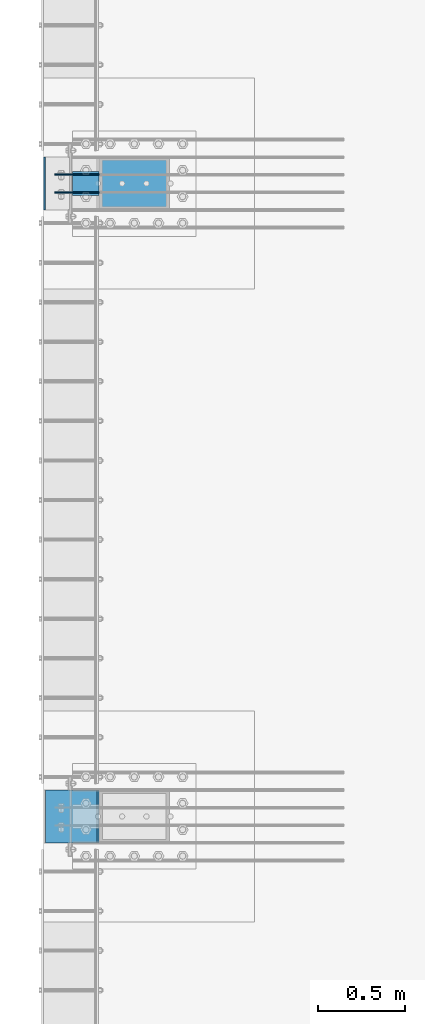
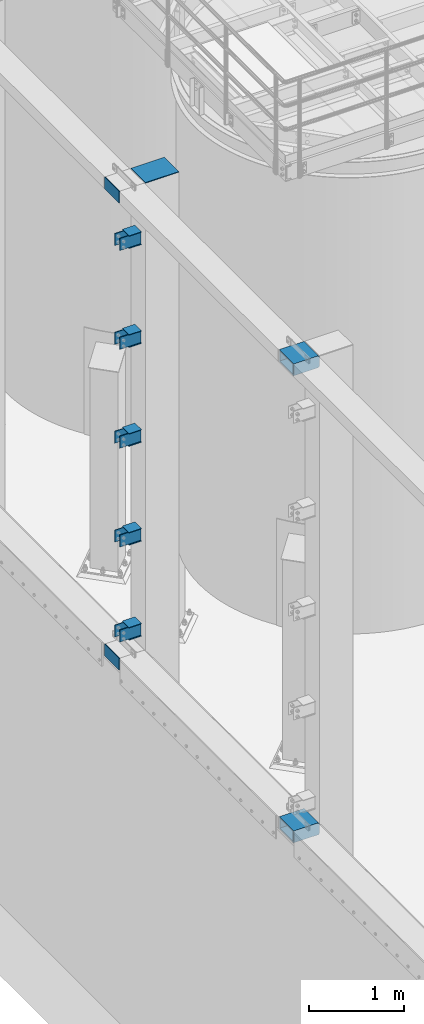
# One storey, part 1091 of 1876: 25 beams, 2 elements without a shape of their own.
"""IFC2X3 building model written with IfcOpenShell, lengths in millimetres."""

import ifcopenshell
import ifcopenshell.guid

model = None  # the IFC model being written
_history = None  # IfcOwnerHistory: only IFC2X3 demands one
_inside = {}  # id of a spatial element -> (the spatial element, [elements in it])
_under = {}  # id of a project, library or spatial element -> (it, [spatial elements below it])
_declared = {}  # id of a project -> (the project, [libraries it declares])
_typed = {}  # id of a type object -> (the type object, [elements of that type])
_made_of = {}  # id of a material, layer set ... -> (it, [elements and type objects made of it])


def new_model(schema):
    """Start an empty IFC model of exactly this schema.

    Asked for "IFC4X3", IfcOpenShell would pick the latest addendum, in which some entities
    have other attributes; the version numbers below select the first issue.
    IFC2X3 requires an IfcOwnerHistory on every rooted entity: one is made here for all.
    """
    global model, _history
    if schema == "IFC4X3":
        model = ifcopenshell.file(schema_version=(4, 3, 0, 0))
    else:
        model = ifcopenshell.file(schema=schema)
    _inside.clear()
    _under.clear()
    _declared.clear()
    _typed.clear()
    _made_of.clear()
    _history = None
    if model.schema == "IFC2X3":
        org = make("IfcOrganization", Name="unknown")
        user = make(
            "IfcPersonAndOrganization",
            ThePerson=make("IfcPerson", FamilyName="unknown"),
            TheOrganization=org,
        )
        app = make(
            "IfcApplication",
            ApplicationDeveloper=org,
            Version="unknown",
            ApplicationFullName="unknown",
            ApplicationIdentifier="unknown",
        )
        _history = make(
            "IfcOwnerHistory",
            OwningUser=user,
            OwningApplication=app,
            ChangeAction="ADDED",
            CreationDate=0,
        )
    return model


def make(cls, **values):
    """One entity of the class cls with the attributes given. An attribute that is None is left unset."""
    return model.create_entity(
        cls, **{name: value for name, value in values.items() if value is not None}
    )


def rooted(cls, **values):
    """An entity with a GlobalId (a new one), such as an element, a storey or a relation."""
    return make(cls, GlobalId=ifcopenshell.guid.new(), OwnerHistory=_history, **values)


def si_unit(unit_type, name, prefix=None):
    """IfcSIUnit, for example si_unit("LENGTHUNIT", "METRE", prefix="MILLI")."""
    return make("IfcSIUnit", UnitType=unit_type, Prefix=prefix, Name=name)


def assignment(units):
    """IfcUnitAssignment: the units of a project."""
    return None if units is None else make("IfcUnitAssignment", Units=units)


def point(xyz):
    """IfcCartesianPoint."""
    return None if xyz is None else make("IfcCartesianPoint", Coordinates=xyz)


def direction(xyz):
    """IfcDirection."""
    return None if xyz is None else make("IfcDirection", DirectionRatios=xyz)


def frame(location, z_axis=None, x_axis=None):
    """IfcAxis2Placement3D, a coordinate frame: its origin and axes. An axis left out is left unset."""
    return make(
        "IfcAxis2Placement3D",
        Location=point(location),
        Axis=direction(z_axis),
        RefDirection=direction(x_axis),
    )


def origin_with_axes():
    """The frame at (0, 0, 0) with the z axis (0, 0, 1) and the x axis (1, 0, 0) written out."""
    return frame((0.0, 0.0, 0.0), z_axis=(0.0, 0.0, 1.0), x_axis=(1.0, 0.0, 0.0))


def place(relative_to, where):
    """IfcLocalPlacement: puts the frame where relative to a parent placement (None: the world)."""
    return make(
        "IfcLocalPlacement", PlacementRelTo=relative_to, RelativePlacement=where
    )


def context(
    kind, dimensions, precision=None, world=None, true_north=None, identifier=None
):
    """IfcGeometricRepresentationContext, for example the 3D "Model" context."""
    return make(
        "IfcGeometricRepresentationContext",
        ContextIdentifier=identifier,
        ContextType=kind,
        CoordinateSpaceDimension=dimensions,
        Precision=precision,
        WorldCoordinateSystem=world,
        TrueNorth=true_north,
    )


def subcontext(parent, identifier, kind, view, scale=None):
    """IfcGeometricRepresentationSubContext, for example "Body" below "Model"."""
    return make(
        "IfcGeometricRepresentationSubContext",
        ContextIdentifier=identifier,
        ContextType=kind,
        ParentContext=parent,
        TargetScale=scale,
        TargetView=view,
    )


def project(units=None, contexts=None):
    """IfcProject with its units and contexts."""
    return rooted(
        "IfcProject",
        Name="project",
        RepresentationContexts=contexts,
        UnitsInContext=assignment(units),
    )


def spatial(cls, under=None, at=None, **own):
    """A site, building, storey or space (cls), placed at a placement, below another one or the project."""
    s = rooted(cls, ObjectPlacement=at, **own)
    if under is not None:
        _under.setdefault(under.id(), (under, []))[1].append(s)
    return s


def faces_of(points, faces, orient=None, outer=None):
    """IfcFace entities. A face is a list of loops; a loop is a list of indices into points, from 0.

    orient and outer hold one flag for each loop. By default every Orientation is true, the
    first loop of a face is its IfcFaceOuterBound and the others are IfcFaceBound.
    """
    made = []
    for i, loops in enumerate(faces):
        bounds = []
        for j, loop in enumerate(loops):
            is_outer = j == 0 if outer is None else outer[i][j]
            bounds.append(
                make(
                    "IfcFaceOuterBound" if is_outer else "IfcFaceBound",
                    Bound=make("IfcPolyLoop", Polygon=[points[k] for k in loop]),
                    Orientation=True if orient is None else orient[i][j],
                )
            )
        made.append(make("IfcFace", Bounds=bounds))
    return made


def faceted_brep(points, faces, orient=None, outer=None, voids=None):
    """IfcFacetedBrep: a solid bounded by flat faces; with voids (closed shells), ...WithVoids."""
    shared = [point(p) for p in points]
    hull = make("IfcClosedShell", CfsFaces=faces_of(shared, faces, orient, outer))
    if voids is None:
        return make("IfcFacetedBrep", Outer=hull)
    return make(
        "IfcFacetedBrepWithVoids",
        Outer=hull,
        Voids=[
            make(cls, CfsFaces=faces_of(shared, fs, o, b)) for cls, fs, o, b in voids
        ],
    )


def shape(context_of_items, identifier, shape_type, items):
    """IfcShapeRepresentation: the items that make up one representation, for example the "Body"."""
    return make(
        "IfcShapeRepresentation",
        ContextOfItems=context_of_items,
        RepresentationIdentifier=identifier,
        RepresentationType=shape_type,
        Items=items,
    )


def material(Name=None, Category=None):
    """IfcMaterial."""
    return make("IfcMaterial", Name=Name, Category=Category)


def made_of(thing, what):
    """Note that an element or type object is made of a material, layer set ...; save() writes the relation."""
    if what is not None:
        _made_of.setdefault(what.id(), (what, []))[1].append(thing)
    return thing


def type_object(cls, material=None, **own):
    """A type object (cls), such as IfcWallType, which elements share."""
    return made_of(rooted(cls, **own), material)


def element(
    cls,
    number,
    at=None,
    inside=None,
    cuts=None,
    type_object=None,
    material=None,
    context=None,
    identifier="Body",
    shape_type=None,
    held_by="IfcProductDefinitionShape",
    body=None,
    shapes=None,
    **own,
):
    """One element of the class cls, such as IfcWall. Its Tag is "e" and its number.

    at: its placement. inside: the storey or other place that contains it. cuts: it is an
    opening in that element (IfcRelVoidsElement). A single representation is given by context,
    identifier, shape_type and body (its items); several are given by shapes. held_by: the class
    of the entity that holds the representations. save() writes the other relations.
    """
    e = rooted(cls, Tag="e%d" % number, ObjectPlacement=at, **own)
    if body is not None:
        shapes = [shape(context, identifier, shape_type, body)]
    if shapes is not None:
        e.Representation = make(held_by, Representations=shapes)
    if inside is not None:
        _inside.setdefault(inside.id(), (inside, []))[1].append(e)
    if cuts is not None:
        rooted(
            "IfcRelVoidsElement", RelatingBuildingElement=cuts, RelatedOpeningElement=e
        )
    if type_object is not None:
        _typed.setdefault(type_object.id(), (type_object, []))[1].append(e)
    return made_of(e, material)


def aggregate(whole, parts):
    """IfcRelAggregates: a whole, such as a stair, and the parts it consists of."""
    return rooted("IfcRelAggregates", RelatingObject=whole, RelatedObjects=parts)


def save(model, path):
    """Write the relations noted so far, then the file.

    IfcRelAggregates (storeys below a building ...), IfcRelContainedInSpatialStructure (elements
    in a storey), IfcRelDefinesByType, IfcRelAssociatesMaterial and IfcRelDeclares: one each for
    every whole, place, type object, material and project.
    """
    for whole, parts in _under.values():
        aggregate(whole, parts)
    for where, things in _inside.values():
        rooted(
            "IfcRelContainedInSpatialStructure",
            RelatedElements=things,
            RelatingStructure=where,
        )
    for kind, things in _typed.values():
        rooted("IfcRelDefinesByType", RelatedObjects=things, RelatingType=kind)
    for what, things in _made_of.values():
        rooted("IfcRelAssociatesMaterial", RelatedObjects=things, RelatingMaterial=what)
    for by, libraries in _declared.values():
        rooted("IfcRelDeclares", RelatingContext=by, RelatedDefinitions=libraries)
    model.write(path)


model = new_model("IFC2X3")

# Units and contexts
model_context = context("Model", 3, precision=1e-05, world=origin_with_axes())
body_context = subcontext(model_context, "Body", "Model", "MODEL_VIEW")
ifc_project = project(units=[si_unit("LENGTHUNIT", "METRE", prefix="MILLI"), si_unit("AREAUNIT", "SQUARE_METRE"), si_unit("VOLUMEUNIT", "CUBIC_METRE"), si_unit("MASSUNIT", "GRAM", prefix="KILO"), si_unit("TIMEUNIT", "SECOND"), si_unit("PLANEANGLEUNIT", "RADIAN"), si_unit("SOLIDANGLEUNIT", "STERADIAN"), si_unit("THERMODYNAMICTEMPERATUREUNIT", "DEGREE_CELSIUS"), si_unit("LUMINOUSINTENSITYUNIT", "LUMEN")], contexts=[model_context])

# Site, building, storey
site_placement = place(None, origin_with_axes())
site = spatial("IfcSite", under=ifc_project, at=site_placement, CompositionType="ELEMENT")
building_placement = place(site_placement, origin_with_axes())
building = spatial("IfcBuilding", under=site, at=building_placement, Name="Undefined", CompositionType="ELEMENT")
storey_placement = place(building_placement, origin_with_axes())
storey = spatial("IfcBuildingStorey", under=building, at=storey_placement, Name="Undefined", CompositionType="ELEMENT", Elevation=0.0)

# Assembly, beams
assembly_1_placement = place(storey_placement, origin_with_axes())
assembly_1 = element("IfcElementAssembly", 1, at=assembly_1_placement, inside=storey, Name="COLUMN", AssemblyPlace="NOTDEFINED", PredefinedType="RIGID_FRAME")
ifc_material_1 = material()
beam_type_1 = type_object("IfcBeamType", Name="HSS12X6X1/2", PredefinedType="NOTDEFINED")
beam_1_placement = place(assembly_1_placement, frame((-301.625, -21742.4, 10591.8), z_axis=(0.0, 1.0, 0.0), x_axis=(1.0, 0.0, 0.0)))
beam_1 = element("IfcBeam", 2, at=beam_1_placement, type_object=beam_type_1, material=ifc_material_1, Name="BEAM", ObjectType="HSS12X6X1/2", context=body_context, shape_type="Brep", body=[
    faceted_brep([(330.199999999997, 63.4999999999982, 152.4), (330.200000000004, 63.5, 139.7), (330.200000000004, 63.5, -139.7), (330.200000000004, 63.4999999999982, -152.4), (318.105151367185, 76.2000000000007, -152.4), (318.105151367185, 76.2000000000007, 152.4), (19.0499999999993, -76.2000000000007, 152.4), (19.0499999999993, -76.2000000000007, -152.4), (318.105151367185, -76.2000000000007, -152.4), (318.105151367185, -76.2000000000007, 152.4), (19.0499999999993, 76.2000000000007, 152.4), (19.0499999999993, 76.2000000000007, -152.4), (19.0499999999993, 63.5, 139.7), (19.0499999999993, -63.5, 139.7), (19.0499999999993, -63.5, -139.7), (19.0499999999993, 63.5, -139.7), (330.200000000004, -63.5, 139.7), (330.200000000004, -63.5, -139.7), (330.199999999997, -63.4999999999982, 152.4), (330.200000000004, -63.4999999999982, -152.4)], [[[0, 1, 2, 3, 4, 5]], [[6, 7, 8, 9]], [[7, 6, 10, 11], [12, 13, 14, 15]], [[14, 13, 16, 17]], [[18, 9, 8, 19, 17, 16]], [[10, 6, 9, 18, 0, 5]], [[11, 10, 5, 4]], [[19, 8, 7, 11, 4, 3]], [[17, 19, 3, 2]], [[15, 14, 17, 2]], [[12, 15, 2, 1]], [[13, 12, 1, 16]], [[18, 16, 1, 0]]]),
])
beam_2_placement = place(assembly_1_placement, frame((-292.1, -21742.4, 4597.4), z_axis=(0.0, 1.0, 0.0), x_axis=(1.0, 0.0, 0.0)))
beam_2 = element("IfcBeam", 3, at=beam_2_placement, type_object=beam_type_1, material=ifc_material_1, Name="BEAM", ObjectType="HSS12X6X1/2", context=body_context, shape_type="Brep", body=[
    faceted_brep([(320.675000000004, 63.5000000000073, 152.400000000001), (320.675000000004, 63.5, 139.700000000001), (320.675000000004, 63.5, -139.700000000001), (320.675000000004, 63.5000000000073, -152.400000000001), (308.580151367183, 76.1999999999998, -152.4), (308.580151367183, 76.1999999999998, 152.4), (9.52499999999452, -76.1999999999998, 152.400000000001), (9.52499999999452, -76.1999999999998, -152.400000000001), (308.580151367183, -76.1999999999998, -152.4), (308.580151367183, -76.1999999999998, 152.4), (9.52499999999452, 76.1999999999998, 152.400000000001), (9.52499999999452, 76.1999999999998, -152.400000000001), (9.52499999999452, 63.5, 139.700000000001), (9.52499999999452, -63.5, 139.700000000001), (9.52499999999452, -63.5, -139.700000000001), (9.52499999999452, 63.5, -139.700000000001), (320.675000000004, -63.5, 139.700000000001), (320.675000000004, -63.5, -139.700000000001), (320.675000000004, -63.5000000000018, 152.400000000001), (320.675000000004, -63.5000000000018, -152.400000000001)], [[[0, 1, 2, 3, 4, 5]], [[6, 7, 8, 9]], [[7, 6, 10, 11], [12, 13, 14, 15]], [[14, 13, 16, 17]], [[18, 9, 8, 19, 17, 16]], [[10, 6, 9, 18, 0, 5]], [[11, 10, 5, 4]], [[19, 8, 7, 11, 4, 3]], [[3, 2, 17, 19]], [[15, 14, 17, 2]], [[12, 15, 2, 1]], [[13, 12, 1, 16]], [[1, 0, 18, 16]]]),
])
aggregate(assembly_1, [beam_1, beam_2])

assembly_2_placement = place(storey_placement, origin_with_axes())
assembly_2 = element("IfcElementAssembly", 4, at=assembly_2_placement, inside=storey, Name="COLUMN", AssemblyPlace="NOTDEFINED", PredefinedType="RIGID_FRAME")
ifc_material_2 = material(Name="STEEL/A36")
beam_type_2 = type_object("IfcBeamType", PredefinedType="NOTDEFINED")
beam_3_placement = place(assembly_2_placement, frame((28.5750000000013, -18137.1875, 4878.3875), z_axis=(0.0, 0.0, -1.0), x_axis=(-1.0, 0.0, 0.0)))
beam_3 = element("IfcBeam", 5, at=beam_3_placement, type_object=beam_type_2, material=ifc_material_2, Name="PLATE", context=body_context, shape_type="Brep", body=[
    faceted_brep([(0.0, 4.76249999999982, -76.1999999999998), (3.63797880709171e-12, 4.76249999999982, 76.1999969482422), (257.174999999999, 4.76249999999982, 76.1999999999998), (257.174999999999, 4.76249999999982, -76.1999999999998), (3.63797880709171e-12, -4.76249999999982, 76.1999969482422), (257.174999999999, -4.76249999999982, 76.1999999999998), (0.0, -4.76249999999982, -76.1999999999998), (257.174999999999, -4.76249999999982, -76.1999999999998)], [[[0, 1, 2, 3]], [[1, 4, 5, 2]], [[4, 6, 7, 5]], [[6, 0, 3, 7]], [[5, 7, 3, 2]], [[6, 4, 1, 0]]]),
])
beam_4_placement = place(assembly_2_placement, frame((28.5750000000013, -18032.4124984741, 4878.3875), z_axis=(0.0, 0.0, -1.0), x_axis=(-1.0, 0.0, 0.0)))
beam_4 = element("IfcBeam", 6, at=beam_4_placement, type_object=beam_type_2, material=ifc_material_2, Name="PLATE", context=body_context, shape_type="Brep", body=[
    faceted_brep([(0.0, 4.76249999999982, -76.1999999999998), (3.63797880709171e-12, 4.76249999999982, 76.1999969482422), (257.174999999999, 4.76249999999982, 76.1999999999998), (257.174999999999, 4.76249999999982, -76.1999999999998), (3.63797880709171e-12, -4.76249999999982, 76.1999969482422), (257.174999999999, -4.76249999999982, 76.1999999999998), (0.0, -4.76249999999982, -76.1999999999998), (257.174999999999, -4.76249999999982, -76.1999999999998)], [[[0, 1, 2, 3]], [[1, 4, 5, 2]], [[4, 6, 7, 5]], [[6, 0, 3, 7]], [[5, 7, 3, 2]], [[6, 4, 1, 0]]]),
])
beam_5_placement = place(assembly_2_placement, frame((28.5750000000013, -18137.1875, 6097.5875), z_axis=(0.0, 0.0, -1.0), x_axis=(-1.0, 0.0, 0.0)))
beam_5 = element("IfcBeam", 7, at=beam_5_placement, type_object=beam_type_2, material=ifc_material_2, Name="PLATE", context=body_context, shape_type="Brep", body=[
    faceted_brep([(0.0, 4.76249999999982, -76.1999999999998), (3.63797880709171e-12, 4.76249999999982, 76.1999969482422), (257.174999999999, 4.76249999999982, 76.1999999999998), (257.174999999999, 4.76249999999982, -76.1999999999998), (3.63797880709171e-12, -4.76249999999982, 76.1999969482422), (257.174999999999, -4.76249999999982, 76.1999999999998), (0.0, -4.76249999999982, -76.1999999999998), (257.174999999999, -4.76249999999982, -76.1999999999998)], [[[0, 1, 2, 3]], [[1, 4, 5, 2]], [[4, 6, 7, 5]], [[6, 0, 3, 7]], [[5, 7, 3, 2]], [[6, 4, 1, 0]]]),
])
beam_6_placement = place(assembly_2_placement, frame((28.5750000000013, -18137.1875, 7366.46302033333), z_axis=(0.0, 0.0, -1.0), x_axis=(-1.0, 0.0, 0.0)))
beam_6 = element("IfcBeam", 8, at=beam_6_placement, type_object=beam_type_2, material=ifc_material_2, Name="PLATE", context=body_context, shape_type="Brep", body=[
    faceted_brep([(0.0, 4.76249999999982, -76.1999999999998), (3.63797880709171e-12, 4.76249999999982, 76.1999969482422), (257.174999999999, 4.76249999999982, 76.1999999999998), (257.174999999999, 4.76249999999982, -76.1999999999998), (3.63797880709171e-12, -4.76249999999982, 76.1999969482422), (257.174999999999, -4.76249999999982, 76.1999999999998), (0.0, -4.76249999999982, -76.1999999999998), (257.174999999999, -4.76249999999982, -76.1999999999998)], [[[0, 1, 2, 3]], [[1, 4, 5, 2]], [[4, 6, 7, 5]], [[6, 0, 3, 7]], [[5, 7, 3, 2]], [[6, 4, 1, 0]]]),
])
beam_7_placement = place(assembly_2_placement, frame((28.5750000000013, -18137.1875, 8635.47083333333), z_axis=(0.0, 0.0, -1.0), x_axis=(-1.0, 0.0, 0.0)))
beam_7 = element("IfcBeam", 9, at=beam_7_placement, type_object=beam_type_2, material=ifc_material_2, Name="PLATE", context=body_context, shape_type="Brep", body=[
    faceted_brep([(0.0, 4.76249999999982, -76.1999999999998), (3.63797880709171e-12, 4.76249999999982, 76.1999969482422), (257.174999999999, 4.76249999999982, 76.1999999999998), (257.174999999999, 4.76249999999982, -76.1999999999998), (3.63797880709171e-12, -4.76249999999982, 76.1999969482422), (257.174999999999, -4.76249999999982, 76.1999999999998), (0.0, -4.76249999999982, -76.1999999999998), (257.174999999999, -4.76249999999982, -76.1999999999998)], [[[0, 1, 2, 3]], [[1, 4, 5, 2]], [[4, 6, 7, 5]], [[6, 0, 3, 7]], [[5, 7, 3, 2]], [[6, 4, 1, 0]]]),
])
beam_8_placement = place(assembly_2_placement, frame((28.5750000000013, -18137.1875, 9904.4125), z_axis=(0.0, 0.0, -1.0), x_axis=(-1.0, 0.0, 0.0)))
beam_8 = element("IfcBeam", 10, at=beam_8_placement, type_object=beam_type_2, material=ifc_material_2, Name="PLATE", context=body_context, shape_type="Brep", body=[
    faceted_brep([(0.0, 4.76249999999982, -76.1999999999998), (3.63797880709171e-12, 4.76249999999982, 76.1999969482422), (257.174999999999, 4.76249999999982, 76.1999999999998), (257.174999999999, 4.76249999999982, -76.1999999999998), (3.63797880709171e-12, -4.76249999999982, 76.1999969482422), (257.174999999999, -4.76249999999982, 76.1999999999998), (0.0, -4.76249999999982, -76.1999999999998), (257.174999999999, -4.76249999999982, -76.1999999999998)], [[[0, 1, 2, 3]], [[1, 4, 5, 2]], [[4, 6, 7, 5]], [[6, 0, 3, 7]], [[5, 7, 3, 2]], [[6, 4, 1, 0]]]),
])
beam_9_placement = place(assembly_2_placement, frame((28.5750000000013, -18032.4124984741, 6097.5875), z_axis=(0.0, 0.0, -1.0), x_axis=(-1.0, 0.0, 0.0)))
beam_9 = element("IfcBeam", 11, at=beam_9_placement, type_object=beam_type_2, material=ifc_material_2, Name="PLATE", context=body_context, shape_type="Brep", body=[
    faceted_brep([(0.0, 4.76249999999982, -76.1999999999998), (3.63797880709171e-12, 4.76249999999982, 76.1999969482422), (257.174999999999, 4.76249999999982, 76.1999999999998), (257.174999999999, 4.76249999999982, -76.1999999999998), (3.63797880709171e-12, -4.76249999999982, 76.1999969482422), (257.174999999999, -4.76249999999982, 76.1999999999998), (0.0, -4.76249999999982, -76.1999999999998), (257.174999999999, -4.76249999999982, -76.1999999999998)], [[[0, 1, 2, 3]], [[1, 4, 5, 2]], [[4, 6, 7, 5]], [[6, 0, 3, 7]], [[5, 7, 3, 2]], [[6, 4, 1, 0]]]),
])
beam_10_placement = place(assembly_2_placement, frame((28.5750000000013, -18032.4124984741, 7366.46302033333), z_axis=(0.0, 0.0, -1.0), x_axis=(-1.0, 0.0, 0.0)))
beam_10 = element("IfcBeam", 12, at=beam_10_placement, type_object=beam_type_2, material=ifc_material_2, Name="PLATE", context=body_context, shape_type="Brep", body=[
    faceted_brep([(0.0, 4.76249999999982, -76.1999999999998), (3.63797880709171e-12, 4.76249999999982, 76.1999969482422), (257.174999999999, 4.76249999999982, 76.1999999999998), (257.174999999999, 4.76249999999982, -76.1999999999998), (3.63797880709171e-12, -4.76249999999982, 76.1999969482422), (257.174999999999, -4.76249999999982, 76.1999999999998), (0.0, -4.76249999999982, -76.1999999999998), (257.174999999999, -4.76249999999982, -76.1999999999998)], [[[0, 1, 2, 3]], [[1, 4, 5, 2]], [[4, 6, 7, 5]], [[6, 0, 3, 7]], [[5, 7, 3, 2]], [[6, 4, 1, 0]]]),
])
beam_11_placement = place(assembly_2_placement, frame((28.5750000000013, -18032.4124984741, 8635.47083333333), z_axis=(0.0, 0.0, -1.0), x_axis=(-1.0, 0.0, 0.0)))
beam_11 = element("IfcBeam", 13, at=beam_11_placement, type_object=beam_type_2, material=ifc_material_2, Name="PLATE", context=body_context, shape_type="Brep", body=[
    faceted_brep([(0.0, 4.76249999999982, -76.1999999999998), (3.63797880709171e-12, 4.76249999999982, 76.1999969482422), (257.174999999999, 4.76249999999982, 76.1999999999998), (257.174999999999, 4.76249999999982, -76.1999999999998), (3.63797880709171e-12, -4.76249999999982, 76.1999969482422), (257.174999999999, -4.76249999999982, 76.1999999999998), (0.0, -4.76249999999982, -76.1999999999998), (257.174999999999, -4.76249999999982, -76.1999999999998)], [[[0, 1, 2, 3]], [[1, 4, 5, 2]], [[4, 6, 7, 5]], [[6, 0, 3, 7]], [[5, 7, 3, 2]], [[6, 4, 1, 0]]]),
])
beam_12_placement = place(assembly_2_placement, frame((28.5750000000013, -18032.4124984741, 9904.4125), z_axis=(0.0, 0.0, -1.0), x_axis=(-1.0, 0.0, 0.0)))
beam_12 = element("IfcBeam", 14, at=beam_12_placement, type_object=beam_type_2, material=ifc_material_2, Name="PLATE", context=body_context, shape_type="Brep", body=[
    faceted_brep([(0.0, 4.76249999999982, -76.1999999999998), (3.63797880709171e-12, 4.76249999999982, 76.1999969482422), (257.174999999999, 4.76249999999982, 76.1999999999998), (257.174999999999, 4.76249999999982, -76.1999999999998), (3.63797880709171e-12, -4.76249999999982, 76.1999969482422), (257.174999999999, -4.76249999999982, 76.1999999999998), (0.0, -4.76249999999982, -76.1999999999998), (257.174999999999, -4.76249999999982, -76.1999999999998)], [[[0, 1, 2, 3]], [[1, 4, 5, 2]], [[4, 6, 7, 5]], [[6, 0, 3, 7]], [[5, 7, 3, 2]], [[6, 4, 1, 0]]]),
])
beam_13_placement = place(assembly_2_placement, frame((-287.337500000001, -18237.2, 4597.4), z_axis=(0.0, 0.0, 1.0), x_axis=(0.0, 1.0, 0.0)))
beam_13 = element("IfcBeam", 15, at=beam_13_placement, type_object=beam_type_2, material=ifc_material_2, Name="PLATE", context=body_context, shape_type="Brep", body=[
    faceted_brep([(0.0, 4.76249999999982, -76.1999999999998), (3.63797880709171e-12, 4.76249999999982, 76.1999969482422), (304.799999999999, 4.76250000000073, 76.1999999999998), (304.799999999999, 4.76250000000073, -76.1999999999998), (3.63797880709171e-12, -4.76249999999982, 76.1999969482422), (304.799999999999, -4.76250000000073, 76.1999999999998), (0.0, -4.76249999999982, -76.1999999999998), (304.799999999999, -4.76250000000073, -76.1999999999998)], [[[0, 1, 2, 3]], [[1, 4, 5, 2]], [[4, 6, 7, 5]], [[6, 0, 3, 7]], [[5, 7, 3, 2]], [[6, 4, 1, 0]]]),
])
beam_14_placement = place(assembly_2_placement, frame((-287.337500000004, -18237.2, 10591.8), z_axis=(0.0, 0.0, 1.0), x_axis=(0.0, 1.0, 0.0)))
beam_14 = element("IfcBeam", 16, at=beam_14_placement, type_object=beam_type_2, material=ifc_material_2, Name="PLATE", context=body_context, shape_type="Brep", body=[
    faceted_brep([(0.0, 4.76249999999982, -76.1999999999998), (3.63797880709171e-12, 4.76249999999982, 76.1999969482422), (304.799999999999, 4.76250000000073, 76.1999999999998), (304.799999999999, 4.76250000000073, -76.1999999999998), (3.63797880709171e-12, -4.76249999999982, 76.1999969482422), (304.799999999999, -4.76250000000073, 76.1999999999998), (0.0, -4.76249999999982, -76.1999999999998), (304.799999999999, -4.76250000000073, -76.1999999999998)], [[[0, 1, 2, 3]], [[1, 4, 5, 2]], [[4, 6, 7, 5]], [[6, 0, 3, 7]], [[5, 7, 3, 2]], [[6, 4, 1, 0]]]),
])
beam_type_3 = type_object("IfcBeamType", PredefinedType="NOTDEFINED")
beam_15_placement = place(assembly_2_placement, frame((28.5750000000031, -18084.8, 4799.0125), z_axis=(0.0, -1.0, 0.0), x_axis=(-1.0, 0.0, 0.0)))
beam_15 = element("IfcBeam", 17, at=beam_15_placement, type_object=beam_type_3, material=ifc_material_2, Name="PLATE", context=body_context, shape_type="Brep", body=[
    faceted_brep([(0.0, 3.17500000000018, -69.8499999999999), (0.0, 3.17500000000018, 69.8499999999999), (152.400000000001, 3.17500000000018, 69.8499999999999), (152.400000000001, 3.17500000000018, -69.8499999999999), (0.0, -3.17500000000018, 69.8499999999999), (152.400000000001, -3.17500000000018, 69.8499999999999), (0.0, -3.17500000000018, -69.8499999999999), (152.400000000001, -3.17500000000018, -69.8499999999999)], [[[0, 1, 2, 3]], [[1, 4, 5, 2]], [[4, 6, 7, 5]], [[6, 0, 3, 7]], [[5, 7, 3, 2]], [[6, 4, 1, 0]]]),
])
beam_16_placement = place(assembly_2_placement, frame((28.5749999999986, -18084.8, 4957.7625), z_axis=(0.0, -1.0, 0.0), x_axis=(-1.0, 0.0, 0.0)))
beam_16 = element("IfcBeam", 18, at=beam_16_placement, type_object=beam_type_3, material=ifc_material_2, Name="PLATE", context=body_context, shape_type="Brep", body=[
    faceted_brep([(0.0, 3.17500000000018, -69.8499999999999), (0.0, 3.17500000000018, 69.8499999999999), (152.400000000001, 3.17500000000018, 69.8499999999999), (152.400000000001, 3.17500000000018, -69.8499999999999), (0.0, -3.17500000000018, 69.8499999999999), (152.400000000001, -3.17500000000018, 69.8499999999999), (0.0, -3.17500000000018, -69.8499999999999), (152.400000000001, -3.17500000000018, -69.8499999999999)], [[[0, 1, 2, 3]], [[1, 4, 5, 2]], [[4, 6, 7, 5]], [[6, 0, 3, 7]], [[5, 7, 3, 2]], [[6, 4, 1, 0]]]),
])
beam_17_placement = place(assembly_2_placement, frame((28.5750000000032, -18084.8, 9825.0375), z_axis=(0.0, -1.0, 0.0), x_axis=(-1.0, 0.0, 0.0)))
beam_17 = element("IfcBeam", 19, at=beam_17_placement, type_object=beam_type_3, material=ifc_material_2, Name="PLATE", context=body_context, shape_type="Brep", body=[
    faceted_brep([(0.0, 3.17500000000018, -69.8499999999999), (0.0, 3.17500000000018, 69.8499999999999), (152.400000000001, 3.17500000000018, 69.8499999999999), (152.400000000001, 3.17500000000018, -69.8499999999999), (0.0, -3.17500000000018, 69.8499999999999), (152.400000000001, -3.17500000000018, 69.8499999999999), (0.0, -3.17500000000018, -69.8499999999999), (152.400000000001, -3.17500000000018, -69.8499999999999)], [[[0, 1, 2, 3]], [[1, 4, 5, 2]], [[4, 6, 7, 5]], [[6, 0, 3, 7]], [[5, 7, 3, 2]], [[6, 4, 1, 0]]]),
])
beam_18_placement = place(assembly_2_placement, frame((28.5749999999986, -18084.8, 9983.7875), z_axis=(0.0, -1.0, 0.0), x_axis=(-1.0, 0.0, 0.0)))
beam_18 = element("IfcBeam", 20, at=beam_18_placement, type_object=beam_type_3, material=ifc_material_2, Name="PLATE", context=body_context, shape_type="Brep", body=[
    faceted_brep([(0.0, 3.17500000000018, -69.8499999999999), (0.0, 3.17500000000018, 69.8499999999999), (152.400000000001, 3.17500000000018, 69.8499999999999), (152.400000000001, 3.17500000000018, -69.8499999999999), (0.0, -3.17500000000018, 69.8499999999999), (152.400000000001, -3.17500000000018, 69.8499999999999), (0.0, -3.17500000000018, -69.8499999999999), (152.400000000001, -3.17500000000018, -69.8499999999999)], [[[0, 1, 2, 3]], [[1, 4, 5, 2]], [[4, 6, 7, 5]], [[6, 0, 3, 7]], [[5, 7, 3, 2]], [[6, 4, 1, 0]]]),
])
beam_19_placement = place(assembly_2_placement, frame((28.5750000000031, -18084.8, 8556.09583333333), z_axis=(0.0, -1.0, 0.0), x_axis=(-1.0, 0.0, 0.0)))
beam_19 = element("IfcBeam", 21, at=beam_19_placement, type_object=beam_type_3, material=ifc_material_2, Name="PLATE", context=body_context, shape_type="Brep", body=[
    faceted_brep([(0.0, 3.17500000000018, -69.8499999999999), (0.0, 3.17500000000018, 69.8499999999999), (152.400000000001, 3.17500000000018, 69.8499999999999), (152.400000000001, 3.17500000000018, -69.8499999999999), (0.0, -3.17500000000018, 69.8499999999999), (152.400000000001, -3.17500000000018, 69.8499999999999), (0.0, -3.17500000000018, -69.8499999999999), (152.400000000001, -3.17500000000018, -69.8499999999999)], [[[0, 1, 2, 3]], [[1, 4, 5, 2]], [[4, 6, 7, 5]], [[6, 0, 3, 7]], [[5, 7, 3, 2]], [[6, 4, 1, 0]]]),
])
beam_20_placement = place(assembly_2_placement, frame((28.5749999999986, -18084.8, 8714.84583333334), z_axis=(0.0, -1.0, 0.0), x_axis=(-1.0, 0.0, 0.0)))
beam_20 = element("IfcBeam", 22, at=beam_20_placement, type_object=beam_type_3, material=ifc_material_2, Name="PLATE", context=body_context, shape_type="Brep", body=[
    faceted_brep([(0.0, 3.17500000000018, -69.8499999999999), (0.0, 3.17500000000018, 69.8499999999999), (152.400000000001, 3.17500000000018, 69.8499999999999), (152.400000000001, 3.17500000000018, -69.8499999999999), (0.0, -3.17500000000018, 69.8499999999999), (152.400000000001, -3.17500000000018, 69.8499999999999), (0.0, -3.17500000000018, -69.8499999999999), (152.400000000001, -3.17500000000018, -69.8499999999999)], [[[0, 1, 2, 3]], [[1, 4, 5, 2]], [[4, 6, 7, 5]], [[6, 0, 3, 7]], [[5, 7, 3, 2]], [[6, 4, 1, 0]]]),
])
beam_21_placement = place(assembly_2_placement, frame((28.5750000000031, -18084.8, 7287.08802033333), z_axis=(0.0, -1.0, 0.0), x_axis=(-1.0, 0.0, 0.0)))
beam_21 = element("IfcBeam", 23, at=beam_21_placement, type_object=beam_type_3, material=ifc_material_2, Name="PLATE", context=body_context, shape_type="Brep", body=[
    faceted_brep([(0.0, 3.17500000000018, -69.8499999999999), (0.0, 3.17500000000018, 69.8499999999999), (152.400000000001, 3.17500000000018, 69.8499999999999), (152.400000000001, 3.17500000000018, -69.8499999999999), (0.0, -3.17500000000018, 69.8499999999999), (152.400000000001, -3.17500000000018, 69.8499999999999), (0.0, -3.17500000000018, -69.8499999999999), (152.400000000001, -3.17500000000018, -69.8499999999999)], [[[0, 1, 2, 3]], [[1, 4, 5, 2]], [[4, 6, 7, 5]], [[6, 0, 3, 7]], [[5, 7, 3, 2]], [[6, 4, 1, 0]]]),
])
beam_22_placement = place(assembly_2_placement, frame((28.5749999999986, -18084.8, 7445.83802033334), z_axis=(0.0, -1.0, 0.0), x_axis=(-1.0, 0.0, 0.0)))
beam_22 = element("IfcBeam", 24, at=beam_22_placement, type_object=beam_type_3, material=ifc_material_2, Name="PLATE", context=body_context, shape_type="Brep", body=[
    faceted_brep([(0.0, 3.17500000000018, -69.8499999999999), (0.0, 3.17500000000018, 69.8499999999999), (152.400000000001, 3.17500000000018, 69.8499999999999), (152.400000000001, 3.17500000000018, -69.8499999999999), (0.0, -3.17500000000018, 69.8499999999999), (152.400000000001, -3.17500000000018, 69.8499999999999), (0.0, -3.17500000000018, -69.8499999999999), (152.400000000001, -3.17500000000018, -69.8499999999999)], [[[0, 1, 2, 3]], [[1, 4, 5, 2]], [[4, 6, 7, 5]], [[6, 0, 3, 7]], [[5, 7, 3, 2]], [[6, 4, 1, 0]]]),
])
beam_23_placement = place(assembly_2_placement, frame((28.5750000000031, -18084.8, 6018.2125), z_axis=(0.0, -1.0, 0.0), x_axis=(-1.0, 0.0, 0.0)))
beam_23 = element("IfcBeam", 25, at=beam_23_placement, type_object=beam_type_3, material=ifc_material_2, Name="PLATE", context=body_context, shape_type="Brep", body=[
    faceted_brep([(0.0, 3.17500000000018, -69.8499999999999), (0.0, 3.17500000000018, 69.8499999999999), (152.400000000001, 3.17500000000018, 69.8499999999999), (152.400000000001, 3.17500000000018, -69.8499999999999), (0.0, -3.17500000000018, 69.8499999999999), (152.400000000001, -3.17500000000018, 69.8499999999999), (0.0, -3.17500000000018, -69.8499999999999), (152.400000000001, -3.17500000000018, -69.8499999999999)], [[[0, 1, 2, 3]], [[1, 4, 5, 2]], [[4, 6, 7, 5]], [[6, 0, 3, 7]], [[5, 7, 3, 2]], [[6, 4, 1, 0]]]),
])
beam_24_placement = place(assembly_2_placement, frame((28.5749999999986, -18084.8, 6176.9625), z_axis=(0.0, -1.0, 0.0), x_axis=(-1.0, 0.0, 0.0)))
beam_24 = element("IfcBeam", 26, at=beam_24_placement, type_object=beam_type_3, material=ifc_material_2, Name="PLATE", context=body_context, shape_type="Brep", body=[
    faceted_brep([(0.0, 3.17500000000018, -69.8499999999999), (0.0, 3.17500000000018, 69.8499999999999), (152.400000000001, 3.17500000000018, 69.8499999999999), (152.400000000001, 3.17500000000018, -69.8499999999999), (0.0, -3.17500000000018, 69.8499999999999), (152.400000000001, -3.17500000000018, 69.8499999999999), (0.0, -3.17500000000018, -69.8499999999999), (152.400000000001, -3.17500000000018, -69.8499999999999)], [[[0, 1, 2, 3]], [[1, 4, 5, 2]], [[4, 6, 7, 5]], [[6, 0, 3, 7]], [[5, 7, 3, 2]], [[6, 4, 1, 0]]]),
])
beam_type_4 = type_object("IfcBeamType", PredefinedType="NOTDEFINED")
beam_25_placement = place(assembly_2_placement, frame((434.974999999999, -18084.8, 10663.2375), z_axis=(0.0, 1.0, 0.0), x_axis=(-1.0, 0.0, 0.0)))
beam_25 = element("IfcBeam", 27, at=beam_25_placement, type_object=beam_type_4, material=ifc_material_2, Name="PLATE", context=body_context, shape_type="Brep", body=[
    faceted_brep([(0.0, 4.76250000000073, -152.4), (0.0, 4.76250000000073, 152.4), (406.400000000001, 4.76250000000073, 152.4), (406.400000000001, 4.76250000000073, -152.4), (0.0, -4.76250000000073, 152.4), (406.400000000001, -4.76250000000073, 152.4), (0.0, -4.76250000000073, -152.4), (406.400000000001, -4.76250000000073, -152.4)], [[[0, 1, 2, 3]], [[1, 4, 5, 2]], [[4, 6, 7, 5]], [[6, 0, 3, 7]], [[5, 7, 3, 2]], [[6, 4, 1, 0]]]),
])
aggregate(assembly_2, [beam_15, beam_16, beam_3, beam_4, beam_17, beam_18, beam_19, beam_20, beam_21, beam_22, beam_23, beam_24, beam_5, beam_6, beam_7, beam_8, beam_9, beam_10, beam_11, beam_12, beam_25, beam_13, beam_14])

save(model, "model.ifc")
